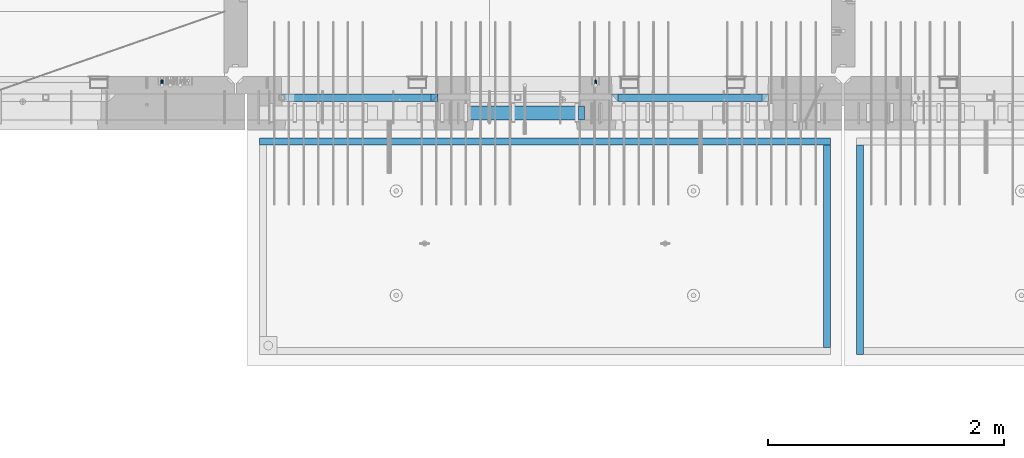
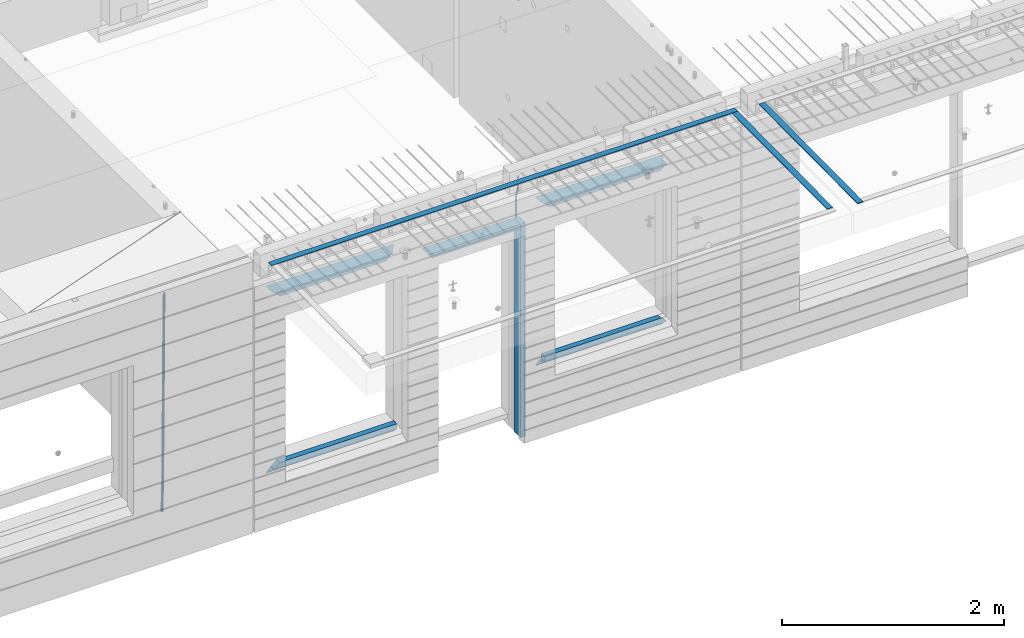
# One storey, part 95 of 352: 15 beams, 4 elements without a shape of their own.
"""IFC2X3 building model written with IfcOpenShell, lengths in millimetres."""

from ifc_helpers import new_model, si_unit, frame, origin_with_axes, place, context, subcontext, project, spatial, faceted_brep, material, type_object, element, aggregate, save


model = new_model("IFC2X3")

# Units and contexts
model_context = context("Model", 3, precision=1e-05, world=origin_with_axes())
body_context = subcontext(model_context, "Body", "Model", "MODEL_VIEW")
ifc_project = project(units=[si_unit("LENGTHUNIT", "METRE", prefix="MILLI"), si_unit("AREAUNIT", "SQUARE_METRE"), si_unit("VOLUMEUNIT", "CUBIC_METRE"), si_unit("MASSUNIT", "GRAM", prefix="KILO"), si_unit("TIMEUNIT", "SECOND"), si_unit("PLANEANGLEUNIT", "RADIAN"), si_unit("SOLIDANGLEUNIT", "STERADIAN"), si_unit("THERMODYNAMICTEMPERATUREUNIT", "DEGREE_CELSIUS"), si_unit("LUMINOUSINTENSITYUNIT", "LUMEN")], contexts=[model_context])

# Site, building, storey
site_placement = place(None, origin_with_axes())
site = spatial("IfcSite", under=ifc_project, at=site_placement, CompositionType="ELEMENT")
building_placement = place(site_placement, origin_with_axes())
building = spatial("IfcBuilding", under=site, at=building_placement, CompositionType="ELEMENT")
storey_placement = place(building_placement, origin_with_axes())
storey = spatial("IfcBuildingStorey", under=building, at=storey_placement, Name="6", CompositionType="ELEMENT", Elevation=0.0)

# Assembly, beam
assembly_1_placement = place(storey_placement, origin_with_axes())
assembly_1 = element("IfcElementAssembly", 1, at=assembly_1_placement, inside=storey, AssemblyPlace="NOTDEFINED", PredefinedType="REINFORCEMENT_UNIT")
ifc_material_1 = material()
beam_type_1 = type_object("IfcBeamType", Name="D20", PredefinedType="NOTDEFINED")
beam_1_placement = place(assembly_1_placement, frame((19710.0073333522, 7925.0, 99407.5000058722), z_axis=(0.000415599999849905, 0.999999913638203, 4.76000000899737e-07), x_axis=(0.0, 0.0, -1.0)))
beam_1 = element("IfcBeam", 2, at=beam_1_placement, type_object=beam_type_1, material=ifc_material_1, Name="JM20", ObjectType="D20", context=body_context, shape_type="Brep", body=[
    faceted_brep([(0.0, -10.0, 0.0), (-4.19531716033816e-08, -7.07106781186667, -7.07106781187031), (113.248091332178, -7.0710684840451, -7.0710678117357), (113.248091314759, -10.0000006713562, -2.51020537689328e-10), (0.0, 0.0, -10.0), (113.248091374131, -6.72178430249915e-07, -9.99999999986903), (4.196772351861e-08, 7.07106781186303, -7.07106781186667), (113.248091416113, 7.07106713968824, -7.07106781173934), (0.0, 10.0, 0.0), (113.248091433488, 9.99999932782521, 1.30967237055302e-10), (4.196772351861e-08, 7.07106781185939, 7.07106781185939), (113.248091416113, 7.0710671396846, 7.071067811994), (0.0, 0.0, 10.0), (113.248091374131, -6.72174792271107e-07, 10.0000000001273), (-4.19531716033816e-08, -7.07106781187031, 7.07106781185939), (113.248091332178, -7.0710684840451, 7.071067811994), (130.699843527167, -7.06993249763036, -4.33745683788584), (128.538066582521, -9.99900540317321, 2.39499413731755), (131.594536475241, 0.00119355250353692, -7.12624594330919), (130.698046432328, 7.07220300913468, -4.33773834422391), (128.535525107087, 10.0009944322555, 2.39459602660281), (126.373748162892, 7.07192152754578, 9.1270470011732), (125.479055214906, 0.000795477419160306, 11.9158361066184), (126.37554525779, -7.07021397921199, 9.12732850753673), (240.336258550378, -7.05529970173666, 30.8729495437874), (238.174481606227, -9.98437260450009, 37.6054005176375), (241.230951498423, 0.0158263482953771, 28.0841604381058), (240.334461455612, 7.0868358050102, 30.8726680369582), (238.171940130502, 10.0156272283348, 37.6050024077231), (236.010163186409, 7.08655432384694, 44.3374533824244), (235.115470238379, 0.0154282738185429, 47.1262424881097), (236.011960281176, -7.05558118289991, 44.3377348892536), (253.461915329972, -7.05444528127919, 32.9289287376414), (253.46191532613, -9.98337746617108, 39.9999965521893), (253.461915339081, 0.0166225284556276, 29.9999965443676), (253.461915348205, 7.08769034247234, 32.9289287273205), (253.461915352003, 10.0166225357716, 39.9999965370152), (253.461915348293, 7.08769035281148, 47.0710643509774), (253.461915339183, 0.0166225430875784, 49.999996544273), (253.46191533003, -7.05444527093641, 47.0710643613093), (1617.47998045172, -7.05444857276962, 32.9289287369675), (1617.47998044467, -9.98338075699212, 39.9999965504549), (1617.47998046874, 0.0166192374708771, 29.9999965449206), (1617.47998048575, 7.08768705096008, 32.9289287291404), (1617.47998049279, 10.0166192430079, 39.9999965393854), (1617.47998048575, 7.08768705878902, 47.071064352871), (1617.47998046874, 0.0166192485448846, 49.9999965449197), (1617.47998045172, -7.05444856494069, 47.0710643606981)], [[[0, 1, 2, 3]], [[1, 4, 5, 2]], [[4, 6, 7, 5]], [[6, 8, 9, 7]], [[8, 10, 11, 9]], [[10, 12, 13, 11]], [[12, 14, 15, 13]], [[14, 0, 3, 15]], [[14, 12, 10, 8, 6, 4, 1, 0]], [[3, 2, 16, 17]], [[2, 5, 18, 16]], [[5, 7, 19, 18]], [[7, 9, 20, 19]], [[9, 11, 21, 20]], [[11, 13, 22, 21]], [[13, 15, 23, 22]], [[15, 3, 17, 23]], [[17, 16, 24, 25]], [[16, 18, 26, 24]], [[18, 19, 27, 26]], [[19, 20, 28, 27]], [[20, 21, 29, 28]], [[21, 22, 30, 29]], [[22, 23, 31, 30]], [[23, 17, 25, 31]], [[25, 24, 32, 33]], [[24, 26, 34, 32]], [[26, 27, 35, 34]], [[27, 28, 36, 35]], [[28, 29, 37, 36]], [[29, 30, 38, 37]], [[30, 31, 39, 38]], [[31, 25, 33, 39]], [[33, 32, 40, 41]], [[32, 34, 42, 40]], [[34, 35, 43, 42]], [[35, 36, 44, 43]], [[36, 37, 45, 44]], [[37, 38, 46, 45]], [[38, 39, 47, 46]], [[39, 33, 41, 47]], [[42, 43, 44, 45, 46, 47, 41, 40]]]),
])

assembly_2_placement = place(storey_placement, origin_with_axes())
assembly_2 = element("IfcElementAssembly", 3, at=assembly_2_placement, inside=storey, AssemblyPlace="NOTDEFINED", PredefinedType="REINFORCEMENT_UNIT")
beam_type_2 = type_object("IfcBeamType", Name="D25", PredefinedType="NOTDEFINED")
beam_2_placement = place(assembly_2_placement, frame((16034.9999999961, 7965.00000227913, 96990.0), z_axis=(0.00020576299992186, -0.999642804629538, -0.0267249099901004), x_axis=(-4.30000201928125e-08, -0.0267249099948059, 0.999642825806181)))
beam_2 = element("IfcBeam", 4, at=beam_2_placement, type_object=beam_type_2, material=ifc_material_1, Name="JM25", ObjectType="D25", context=body_context, shape_type="Brep", body=[
    faceted_brep([(-7.41420080885291e-08, -12.5, -3.63797880709171e-12), (-6.42030499875546e-08, -10.8253175473074, -6.25000000000364), (60.4103898235917, -10.8253175318459, -6.2499999938409), (60.4103898269532, -12.4999999845422, 6.16273609921336e-09), (-3.70782800018787e-08, -6.25000000000364, -10.8253175473074), (60.4103898202884, -6.24999998454587, -10.8253175411446), (-1.45519152283669e-11, -3.63797880709171e-12, -12.5), (60.4103898179019, 1.54577719513327e-08, -12.4999999938373), (3.70637280866504e-08, 6.25, -10.8253175473074), (60.410389817087, 6.25000001545777, -10.825317541141), (6.42030499875546e-08, 10.8253175473001, -6.25000000000364), (60.410389818062, 10.8253175627578, -6.24999999383726), (7.41420080885291e-08, 12.4999999999927, 0.0), (60.4103898205503, 12.5000000154541, 6.16273609921336e-09), (6.42176019027829e-08, 10.8253175473001, 6.24999999999636), (60.4103898238973, 10.8253175627651, 6.2500000061591), (3.70928319171071e-08, 6.24999999999636, 10.8253175473037), (60.4103898272151, 6.25000001546141, 10.8253175534664), (1.45519152283669e-11, -3.63797880709171e-12, 12.4999999999964), (60.4103898296162, 1.54541339725256e-08, 12.5000000061591), (-3.7049176171422e-08, -6.25000000000364, 10.8253175473001), (60.4103898304165, -6.24999998454587, 10.8253175534701), (-6.41884980723262e-08, -10.8253175473074, 6.25), (60.4103898294561, -10.8253175318459, 6.25000000616637), (61.0324985728803, -10.8253175316895, -6.24999999377542), (60.991802792938, -12.4999999843931, 6.22458173893392e-09), (61.0622854283865, -6.24999998437852, -10.8253175410755), (61.0731819955545, 1.5628756955266e-08, -12.4999999937718), (61.0622685480339, 6.25000001562512, -10.8253175410791), (61.032469335245, 10.8253175629216, -6.24999999377178), (60.9917690322181, 12.5000000156033, 6.22458173893392e-09), (60.9510732522613, 10.8253175629034, 6.25000000621731), (60.9212863967696, 6.25000001558874, 10.8253175535247), (60.9103898296162, 1.55814632307738e-08, 12.5000000062137), (60.9213032771368, -6.24999998441126, 10.8253175535174), (60.9511024898966, -10.8253175317113, 6.25000000621731), (61.6545545670233, -10.8253158516927, -6.24189838219536), (61.573166454793, -12.499998414296, 0.00757164385504439), (61.7141257553885, -6.24999822394238, -10.8168280205282), (61.7359179680789, 1.80548886419274e-06, -12.491368569139), (61.7140919992817, 6.25000177601396, -10.8168282403167), (61.6544960997562, 10.8253192428383, -6.2418987628771), (61.5730989426083, 12.5000015856094, 0.0075712042817031), (61.4917108303925, 10.8253190230062, 6.25704123032847), (61.4321396420273, 6.25000139525582, 10.8319708686649), (61.4103474293224, 1.36582457344048e-06, 12.5065114172721), (61.4321733981196, -6.24999860470052, 10.8319710884571), (61.4917692976451, -10.8253160715249, 6.25704161101385), (176.524302641745, -10.8250056210964, -4.74584321979273), (176.442914529529, -12.4996881836996, 1.50362680625403), (176.583873830095, -6.24968799334965, -9.3207728581292), (176.605666042786, 0.000312036081595579, -10.9953134067364), (176.583840074018, 6.25031200660669, -9.32077307791769), (176.524244174492, 10.8256294734347, -4.74584360047811), (176.44284701733, 12.5003118162058, 1.50362636668069), (176.361458905099, 10.8256292535989, 7.75309639272746), (176.301887716749, 6.25031162585219, 12.3280260310676), (176.280095504058, 0.000311596420942806, 14.0025665796711), (176.301921472827, -6.24968837410415, 12.3280262508561), (176.361517372367, -10.8250058409321, 7.75309677341284), (177.085397012124, -10.8250041057399, -4.73853556792164), (176.983633547483, -12.4996867233749, 1.51066909103247), (177.159881729676, -6.24968643771717, -9.31327097355097), (177.187129580227, 0.000313606451527448, -10.987740468332), (177.159839524218, 6.25031356221734, -9.31327130338468), (177.085323910098, 10.8256309887511, -4.73853613920801), (176.983549136537, 12.5003132764905, 1.51066843136869), (176.881785671867, 10.8256306588555, 7.7598730903228), (176.80730095433, 6.25031299082912, 12.3346084959521), (176.780053103794, 0.000312946667690994, 14.0090779907332), (176.807343159802, -6.2496870091054, 12.3346088257895), (176.881858773908, -10.8250044356355, 7.7598736616128), (177.646431799818, -10.8250018318176, -4.72756919822132), (177.524295146417, -12.4996845320202, 1.52123723245313), (177.735828462886, -6.24968410334986, -9.30201312475765), (177.768531371941, 0.00031596292683389, -10.9763759912421), (177.735777808921, 6.25031589654827, -9.30201361973741), (177.646344064575, 10.8256332626152, -4.72757005553649), (177.524193838486, 12.5003154677688, 1.52123624250817), (177.402057185071, 10.8256327675663, 7.77004267317898), (177.312660521988, 6.2503150390985, 12.3444865997226), (177.279957612933, 0.00031497282179771, 14.0188494661961), (177.312711175953, -6.24968496079964, 12.3444870946951), (177.402144920314, -10.8250023268702, 7.77004353049415), (299.377443161706, -10.8245084454466, -2.34813158632096), (299.255306508276, -12.4991911456491, 3.90067484435349), (299.466839824803, -6.24919071697514, -6.92257551286093), (299.499542733873, 0.0008093492979242, -8.59693837933446), (299.466789170867, 6.250809282923, -6.92257600783341), (299.377355426492, 10.8261266489935, -2.34813244364341), (299.255205200388, 12.5008088541435, 3.90067385440125), (299.133068546944, 10.826126153941, 10.1494802850757), (299.043671883861, 6.25080842546959, 14.7239242116229), (299.010968974762, 0.000808359200163977, 16.3982870780892), (299.043722537797, -6.24919157442127, 14.7239247065918), (299.133156282158, -10.8245089404954, 10.1494811423981), (299.98561436501, -10.8245059804758, -2.33624385599614), (299.97179243555, -12.4991882411778, 3.91467976726199), (299.995742293278, -6.24918857328521, -6.91223722345239), (299.999447243041, 0.000811375455668895, -8.58716690387519), (299.995736475976, 6.25081142679483, -6.91223684201032), (299.985604289133, 10.8261291142808, -2.33624319533556), (299.971750386685, 12.5008117588586, 3.91467993563856), (299.957928457196, 10.8261294971744, 10.1656035610831), (299.947800528913, 6.25081208998381, 14.7415969285394), (299.944095579151, 0.00081214124293183, 16.4165266089549), (299.947806346216, -6.24918791008895, 14.7415965471009), (299.957938533058, -10.8245055975785, 10.1656029004225), (300.593832239858, -10.8245078794353, -2.34543881707941), (300.688302931099, -12.4991904788549, 3.90384712594823), (300.524685350189, -6.24919022474205, -6.92023371784308), (300.499390115292, 0.000809814544481924, -8.59472497713432), (300.524724372954, 6.25080977519247, -6.92023401429469), (300.593899829313, 10.8261272150703, -2.34543933054374), (300.688380976673, 12.5008095210287, 3.90384653304136), (300.782851667915, 10.8261269216127, 10.1531324760799), (300.851998557599, 6.25080926691589, 14.7279273768363), (300.877293792495, 0.000809227632998955, 16.4024186361276), (300.851959534804, -6.24919073302226, 14.7279276732806), (300.782784078474, -10.8245081728965, 10.153132989537), (2293.32930409742, -10.8307295605009, -32.4713622331001), (2293.42377478865, -12.5054121599169, -26.2220762900724), (2293.26015720774, -6.2554119058077, -37.0461571338565), (2293.23486197284, -0.00541186651753378, -38.7206483931477), (2293.26019623051, 6.24458809413409, -37.0461574303008), (2293.32937168686, 10.8199055340046, -32.4713627465644), (2293.42385283421, 12.4945878399631, -26.2220768829684), (2293.51832352545, 10.8199052405434, -19.972790939948), (2293.58747041514, 6.24458758585388, -15.3979960391844), (2293.61276565003, -0.00541245343265473, -13.7235047798931), (2293.58743139236, -6.25541241408428, -15.3979957427327), (2293.51825593603, -10.8307298539585, -19.9727904264691), (2294.0420846676, -10.8307317859326, -32.4821379598216), (2294.03681932652, -12.5054140739521, -26.2313442200393), (2294.06778164886, -6.2554144273563, -37.0583666982457), (2294.10702478497, -0.00541458957013674, -38.7338336404937), (2294.14929890928, 6.24458531819619, -37.0595987724118), (2294.18327670435, 10.8199028679592, -32.4842719748667), (2294.1998538474, 12.4945854171456, -26.2338083683717), (2294.19458850632, 10.819903129126, -19.9830146285858), (2294.16889152506, 6.24458577054975, -15.4067858901581), (2294.12964838895, -0.0054140672327776, -13.7313189479173), (2294.08737426462, -6.2554139749991, -15.4055538159919), (2294.05339646956, -10.8307315247621, -19.9808806135297), (2294.75482297382, -10.84002603931, -32.4726521173216), (2294.64982751427, -12.513407826169, -26.2231856868602), (2294.87535820232, -6.26594539088183, -37.0476186524102), (2294.97913588268, -0.0167870967634371, -38.7222267036377), (2295.0383488692, 6.23299192477134, -37.0477663960555), (2295.03713108998, 10.8087684320271, -32.4729080168181), (2294.97580884799, 12.4844668051373, -26.2234811741473), (2294.87081338844, 10.8110850182784, -19.9740147436787), (2294.7502781599, 6.23700436985018, -15.3990482086047), (2294.64650047956, -0.0121539242718427, -13.7244401573698), (2294.58728749304, -6.26193294580662, -15.3989004649666), (2294.58850527227, -10.8377094530588, -19.9737588441894), (2316.44667268227, -11.1228921988077, -32.1839550346631), (2316.34167722271, -12.7962739856739, -25.9344886042054), (2316.56720791078, -6.54881155039038, -36.7589215697517), (2316.67098559113, -0.299653256264719, -38.4335296209792), (2316.73019857766, 5.95012576527006, -36.759069313397), (2316.72898079845, 10.5259022725259, -32.1842109341669), (2316.66765855643, 12.2016006456361, -25.9347840914961), (2316.56266309689, 10.5282188587698, -19.6853176610275), (2316.44212786836, 5.95413821035254, -15.1103511259389), (2316.33835018802, -0.295020083769487, -13.4357430747186), (2316.27913720149, -6.54479910530426, -15.1102033823008), (2316.28035498071, -11.1205756125637, -19.685061761531), (2317.13234804722, -11.1318335458927, -32.1748293731798), (2317.04181141085, -12.8054038787741, -25.9251705100723), (2317.2154741603, -6.5572650749491, -36.7502937866229), (2317.26891617525, -0.307450393454928, -38.4255717558117), (2317.27835434731, 5.94297770185585, -36.7517739018112), (2317.24125972588, 10.5192220504723, -32.1773930078925), (2317.16757178486, 12.1950816748285, -25.9281307404563), (2317.0770351485, 10.5215113419545, -19.6784718773561), (2316.99390903539, 5.94694287101083, -15.1030074639057), (2316.94046702047, -0.302871810494253, -13.4277294947169), (2316.9310288484, -6.55329990579412, -15.1015273487101), (2316.96812346982, -11.1295442544142, -19.6759082426288), (2317.81808136747, -11.1298054502913, -32.1659056455355), (2317.74200467508, -12.803315894289, -25.9160547315114), (2317.86379538118, -6.55536082026447, -36.7418676070083), (2317.8668976831, -0.305700748642266, -38.417815303761), (2317.82655701396, 5.94458339541234, -36.7446799039099), (2317.75358262347, 10.5207330230332, -32.1707766866384), (2317.66752794063, 12.1965725370646, -25.9216793252963), (2317.59145124823, 10.5230620930706, -19.6718284112721), (2317.54573723453, 5.94861746304377, -15.0958664497994), (2317.54263493262, -0.301042608574789, -13.4199187530394), (2317.58297560175, -6.55132675263303, -15.0930541529051), (2317.65594999224, -11.1274763802539, -19.6669573701693), (2417.81884292323, -10.831603083323, -30.8687911350135), (2417.74276623082, -12.505113527317, -24.618940220982), (2417.86455693691, -6.25715845329614, -35.4447530964935), (2417.86765923884, -0.00749838167394046, -37.1207007932499), (2417.82731856969, 6.24278576237703, -35.4475653933878), (2417.75434417921, 10.8189353900088, -30.8736621761236), (2417.66828949639, 12.494774904033, -24.6245648147851), (2417.59221280397, 10.8212644600353, -18.3747139007501), (2417.54649879028, 6.2468198300121, -13.79875193927), (2417.54339648837, -0.00284024161010166, -12.1228042425173), (2417.5837371575, -6.25312438566107, -13.795939642383), (2417.65671154798, -10.8292740132893, -18.3698428596399)], [[[0, 1, 2, 3]], [[1, 4, 5, 2]], [[4, 6, 7, 5]], [[6, 8, 9, 7]], [[8, 10, 11, 9]], [[10, 12, 13, 11]], [[12, 14, 15, 13]], [[14, 16, 17, 15]], [[16, 18, 19, 17]], [[18, 20, 21, 19]], [[20, 22, 23, 21]], [[22, 0, 3, 23]], [[22, 20, 18, 16, 14, 12, 10, 8, 6, 4, 1, 0]], [[3, 2, 24, 25]], [[2, 5, 26, 24]], [[5, 7, 27, 26]], [[7, 9, 28, 27]], [[9, 11, 29, 28]], [[11, 13, 30, 29]], [[13, 15, 31, 30]], [[15, 17, 32, 31]], [[17, 19, 33, 32]], [[19, 21, 34, 33]], [[21, 23, 35, 34]], [[23, 3, 25, 35]], [[25, 24, 36, 37]], [[24, 26, 38, 36]], [[26, 27, 39, 38]], [[27, 28, 40, 39]], [[28, 29, 41, 40]], [[29, 30, 42, 41]], [[30, 31, 43, 42]], [[31, 32, 44, 43]], [[32, 33, 45, 44]], [[33, 34, 46, 45]], [[34, 35, 47, 46]], [[35, 25, 37, 47]], [[37, 36, 48, 49]], [[36, 38, 50, 48]], [[38, 39, 51, 50]], [[39, 40, 52, 51]], [[40, 41, 53, 52]], [[41, 42, 54, 53]], [[42, 43, 55, 54]], [[43, 44, 56, 55]], [[44, 45, 57, 56]], [[45, 46, 58, 57]], [[46, 47, 59, 58]], [[47, 37, 49, 59]], [[49, 48, 60, 61]], [[48, 50, 62, 60]], [[50, 51, 63, 62]], [[51, 52, 64, 63]], [[52, 53, 65, 64]], [[53, 54, 66, 65]], [[54, 55, 67, 66]], [[55, 56, 68, 67]], [[56, 57, 69, 68]], [[57, 58, 70, 69]], [[58, 59, 71, 70]], [[59, 49, 61, 71]], [[61, 60, 72, 73]], [[60, 62, 74, 72]], [[62, 63, 75, 74]], [[63, 64, 76, 75]], [[64, 65, 77, 76]], [[65, 66, 78, 77]], [[66, 67, 79, 78]], [[67, 68, 80, 79]], [[68, 69, 81, 80]], [[69, 70, 82, 81]], [[70, 71, 83, 82]], [[71, 61, 73, 83]], [[73, 72, 84, 85]], [[72, 74, 86, 84]], [[74, 75, 87, 86]], [[75, 76, 88, 87]], [[76, 77, 89, 88]], [[77, 78, 90, 89]], [[78, 79, 91, 90]], [[79, 80, 92, 91]], [[80, 81, 93, 92]], [[81, 82, 94, 93]], [[82, 83, 95, 94]], [[83, 73, 85, 95]], [[85, 84, 96, 97]], [[84, 86, 98, 96]], [[86, 87, 99, 98]], [[87, 88, 100, 99]], [[88, 89, 101, 100]], [[89, 90, 102, 101]], [[90, 91, 103, 102]], [[91, 92, 104, 103]], [[92, 93, 105, 104]], [[93, 94, 106, 105]], [[94, 95, 107, 106]], [[95, 85, 97, 107]], [[97, 96, 108, 109]], [[96, 98, 110, 108]], [[98, 99, 111, 110]], [[99, 100, 112, 111]], [[100, 101, 113, 112]], [[101, 102, 114, 113]], [[102, 103, 115, 114]], [[103, 104, 116, 115]], [[104, 105, 117, 116]], [[105, 106, 118, 117]], [[106, 107, 119, 118]], [[107, 97, 109, 119]], [[109, 108, 120, 121]], [[108, 110, 122, 120]], [[110, 111, 123, 122]], [[111, 112, 124, 123]], [[112, 113, 125, 124]], [[113, 114, 126, 125]], [[114, 115, 127, 126]], [[115, 116, 128, 127]], [[116, 117, 129, 128]], [[117, 118, 130, 129]], [[118, 119, 131, 130]], [[119, 109, 121, 131]], [[121, 120, 132, 133]], [[120, 122, 134, 132]], [[122, 123, 135, 134]], [[123, 124, 136, 135]], [[124, 125, 137, 136]], [[125, 126, 138, 137]], [[126, 127, 139, 138]], [[127, 128, 140, 139]], [[128, 129, 141, 140]], [[129, 130, 142, 141]], [[130, 131, 143, 142]], [[131, 121, 133, 143]], [[133, 132, 144, 145]], [[132, 134, 146, 144]], [[134, 135, 147, 146]], [[135, 136, 148, 147]], [[136, 137, 149, 148]], [[137, 138, 150, 149]], [[138, 139, 151, 150]], [[139, 140, 152, 151]], [[140, 141, 153, 152]], [[141, 142, 154, 153]], [[142, 143, 155, 154]], [[143, 133, 145, 155]], [[145, 144, 156, 157]], [[144, 146, 158, 156]], [[146, 147, 159, 158]], [[147, 148, 160, 159]], [[148, 149, 161, 160]], [[149, 150, 162, 161]], [[150, 151, 163, 162]], [[151, 152, 164, 163]], [[152, 153, 165, 164]], [[153, 154, 166, 165]], [[154, 155, 167, 166]], [[155, 145, 157, 167]], [[157, 156, 168, 169]], [[156, 158, 170, 168]], [[158, 159, 171, 170]], [[159, 160, 172, 171]], [[160, 161, 173, 172]], [[161, 162, 174, 173]], [[162, 163, 175, 174]], [[163, 164, 176, 175]], [[164, 165, 177, 176]], [[165, 166, 178, 177]], [[166, 167, 179, 178]], [[167, 157, 169, 179]], [[169, 168, 180, 181]], [[168, 170, 182, 180]], [[170, 171, 183, 182]], [[171, 172, 184, 183]], [[172, 173, 185, 184]], [[173, 174, 186, 185]], [[174, 175, 187, 186]], [[175, 176, 188, 187]], [[176, 177, 189, 188]], [[177, 178, 190, 189]], [[178, 179, 191, 190]], [[179, 169, 181, 191]], [[181, 180, 192, 193]], [[180, 182, 194, 192]], [[182, 183, 195, 194]], [[183, 184, 196, 195]], [[184, 185, 197, 196]], [[185, 186, 198, 197]], [[186, 187, 199, 198]], [[187, 188, 200, 199]], [[188, 189, 201, 200]], [[189, 190, 202, 201]], [[190, 191, 203, 202]], [[191, 181, 193, 203]], [[194, 195, 196, 197, 198, 199, 200, 201, 202, 203, 193, 192]]]),
])
aggregate(assembly_2, [beam_2])

assembly_3_placement = place(storey_placement, origin_with_axes())
assembly_3 = element("IfcElementAssembly", 5, at=assembly_3_placement, inside=storey, AssemblyPlace="NOTDEFINED", PredefinedType="REINFORCEMENT_UNIT")
ifc_material_2 = material(Name="CONCRETE/Concrete_Undefined")
beam_type_3 = type_object("IfcBeamType", PredefinedType="NOTDEFINED")
beam_3_placement = place(assembly_3_placement, frame((21949.9413897781, 7420.05314849477, 99725.6636561746), z_axis=(2.93000000986506e-07, -0.00901322400064496, 0.999959380071525), x_axis=(3.25389999851993e-05, -0.999959379542196, -0.00901322399586982)))
beam_3 = element("IfcBeam", 6, at=beam_3_placement, type_object=beam_type_3, material=ifc_material_2, context=body_context, shape_type="Brep", body=[
    faceted_brep([(2.5465851649642e-11, 29.9999999999982, -4.99999999998545), (-2.91038304567337e-11, 29.9999999999982, 5.0), (1775.16788460852, 30.0000000000036, 5.0), (1775.16788460861, 30.0000000000036, -4.99999999998545), (-2.5465851649642e-11, -30.0000000000018, 5.0), (1775.16788460852, -29.9999999999927, 5.0), (2.72848410531878e-11, -30.0000000000018, -4.99999999998545), (1775.16788460861, -29.9999999999927, -4.99999999998545)], [[[0, 1, 2, 3]], [[1, 4, 5, 2]], [[4, 6, 7, 5]], [[6, 0, 3, 7]], [[5, 7, 3, 2]], [[6, 4, 1, 0]]]),
])
aggregate(assembly_3, [beam_3])

# Assembly, beams
assembly_4_placement = place(storey_placement, origin_with_axes())
assembly_4 = element("IfcElementAssembly", 7, at=assembly_4_placement, inside=storey, AssemblyPlace="NOTDEFINED", PredefinedType="REINFORCEMENT_UNIT")
beam_4_placement = place(assembly_4_placement, frame((21670.0013901233, 7419.93998011425, 99723.2790373903), z_axis=(-5.99999839176643e-09, -0.0089070149978186, 0.99996033175513), x_axis=(-7.26999998800451e-07, -0.999960331754865, -0.00890701499781462)))
beam_4 = element("IfcBeam", 8, at=beam_4_placement, type_object=beam_type_3, material=ifc_material_2, context=body_context, shape_type="Brep", body=[
    faceted_brep([(2.5465851649642e-11, 29.9999999999982, -4.99999999998545), (-2.91038304567337e-11, 29.9999999999982, 5.0), (1714.98205429674, 30.0, 5.00000000001455), (1714.98205429674, 30.0000000000036, -4.99999999998545), (-2.5465851649642e-11, -30.0000000000018, 5.0), (1714.98205429674, -30.0, 5.00000000001455), (2.72848410531878e-11, -30.0000000000018, -4.99999999998545), (1714.98205429674, -29.9999999999964, -4.99999999998545)], [[[0, 1, 2, 3]], [[1, 4, 5, 2]], [[4, 6, 7, 5]], [[6, 0, 3, 7]], [[5, 7, 3, 2]], [[6, 4, 1, 0]]]),
])
beam_5_placement = place(assembly_4_placement, frame((21700.0027302922, 7449.93184428734, 99723.6588442717), z_axis=(0.0, 0.0, 1.0), x_axis=(-0.999999999888168, 1.49249999983396e-05, 9.53000001204034e-07)))
beam_5 = element("IfcBeam", 9, at=beam_5_placement, type_object=beam_type_3, material=ifc_material_2, context=body_context, shape_type="Brep", body=[
    faceted_brep([(2.5465851649642e-11, 29.9999999999982, -4.99999999998545), (-2.91038304567337e-11, 29.9999999999982, 5.0), (4840.00999799337, 29.9999999999991, 5.0), (4840.00999799337, 29.9999999999982, -5.00000000001455), (-2.5465851649642e-11, -30.0000000000018, 5.0), (4840.00999799337, -30.0000000000009, 5.0), (2.72848410531878e-11, -30.0000000000018, -4.99999999998545), (4840.00999799337, -30.0000000000009, -5.0)], [[[0, 1, 2, 3]], [[1, 4, 5, 2]], [[4, 6, 7, 5]], [[6, 0, 3, 7]], [[5, 7, 3, 2]], [[6, 4, 1, 0]]]),
])
aggregate(assembly_4, [beam_4, beam_5])

# Beam
ifc_material_3 = material(Name="CONCRETE/C35/45")
beam_type_4 = type_object("IfcBeamType", PredefinedType="NOTDEFINED")
beam_6_placement = place(assembly_1_placement, frame((17044.9994828029, 7820.0, 99145.0), z_axis=(0.0, 0.0, -1.0), x_axis=(1.0, 0.0, 0.0)))
beam_6 = element("IfcBeam", 10, at=beam_6_placement, type_object=beam_type_4, material=ifc_material_3, Name="SK", context=body_context, shape_type="Brep", body=[
    faceted_brep([(0.0, -30.0, -30.0), (49.817662327685, -30.0, 30.0), (49.817662327685, 30.0, 30.0), (1330.00114440918, -30.0, -30.0), (1280.18348208149, -30.0, 30.0), (1280.18348208149, 30.0, 30.0)], [[[0, 1, 2]], [[1, 0, 3, 4]], [[2, 1, 4, 5]], [[0, 2, 5, 3]], [[4, 3, 5]]]),
])

beam_7_placement = place(assembly_1_placement, frame((17104.9994828029, 7820.0, 99085.0), z_axis=(0.0, 0.0, -1.0), x_axis=(1.0, 0.0, 0.0)))
beam_7 = element("IfcBeam", 11, at=beam_7_placement, type_object=beam_type_4, material=ifc_material_3, Name="SK", context=body_context, shape_type="Brep", body=[
    faceted_brep([(0.0, -30.0, -30.0), (53.0959879499314, -30.0, 24.0540540540678), (54.6888675884184, 30.0, 25.6756756756804), (0.0, 30.0, -30.0), (1210.00114440918, -30.0, -30.0), (1156.90515645927, -30.0, 24.0540540540678), (1155.31227682078, 30.0, 25.6756756756804), (1210.00114440918, 30.0, -30.0)], [[[0, 1, 2, 3]], [[1, 0, 4, 5]], [[2, 1, 5, 6]], [[3, 2, 6, 7]], [[0, 3, 7, 4]], [[6, 5, 4, 7]]]),
])

beam_8_placement = place(assembly_1_placement, frame((18375.0006272121, 7820.0, 97150.0), z_axis=(0.0, 0.0, 1.0), x_axis=(-1.0, 3.00000001838171e-08, 0.0)))
beam_8 = element("IfcBeam", 12, at=beam_8_placement, type_object=beam_type_4, material=ifc_material_3, Name="SK", context=body_context, shape_type="Brep", body=[
    faceted_brep([(0.0, -30.0, 30.0), (-5.28234522789717e-09, 30.0, 30.0), (0.0, -30.0, -30.0), (1280.18348208149, -30.0, 30.0), (1280.18348208149, 30.0, 30.0), (1330.00114440918, -30.0, -30.0)], [[[0, 1, 2]], [[1, 0, 3, 4]], [[2, 1, 4, 5]], [[0, 2, 5, 3]], [[3, 5, 4]]]),
])

beam_9_placement = place(assembly_1_placement, frame((18375.0006272121, 7820.0, 97210.0), z_axis=(0.0, 0.0, 1.0), x_axis=(-1.0, 3.00000001838171e-08, 0.0)))
beam_9 = element("IfcBeam", 13, at=beam_9_placement, type_object=beam_type_4, material=ifc_material_3, Name="SK", context=body_context, shape_type="Brep", body=[
    faceted_brep([(0.0, -30.0, -30.0), (0.0, -30.0, 30.0), (-5.28234522789717e-09, 30.0, 30.0), (0.0, 30.0, -30.0), (4.05405405405327, -30.0, 30.0), (5.67567567567312, 30.0, 30.0), (4.05405405404963, -30.0, 24.0540540540533), (5.67567567567312, 30.0, 25.6756756756804), (1215.31227682077, 30.0, 25.6756756756804), (1270.00114440918, 30.0, -30.0), (1270.00114440918, -30.0, -30.0), (1216.90515645926, -30.0, 24.0540540540678)], [[[0, 1, 2, 3]], [[2, 1, 4, 5]], [[4, 6, 7, 5]], [[3, 2, 5, 7, 8, 9]], [[0, 3, 9, 10]], [[6, 4, 1, 0, 10, 11]], [[7, 6, 11, 8]], [[10, 9, 8, 11]]]),
])

beam_10_placement = place(assembly_1_placement, frame((19845.0006272121, 7820.0, 99145.0), z_axis=(0.0, 0.0, -1.0), x_axis=(1.0, 0.0, 0.0)))
beam_10 = element("IfcBeam", 14, at=beam_10_placement, type_object=beam_type_4, material=ifc_material_3, Name="SK", context=body_context, shape_type="Brep", body=[
    faceted_brep([(0.0, -30.0, -30.0), (49.817662327685, -30.0, 30.0), (49.817662327685, 30.0, 30.0), (1329.99923706055, -30.0, -30.0), (1280.18157473286, -30.0, 30.0), (1280.18157473286, 30.0, 30.0)], [[[0, 1, 2]], [[1, 0, 3, 4]], [[2, 1, 4, 5]], [[0, 2, 5, 3]], [[4, 3, 5]]]),
])

beam_11_placement = place(assembly_1_placement, frame((19905.0006272121, 7820.0, 99085.0), z_axis=(0.0, 0.0, -1.0), x_axis=(1.0, 0.0, 0.0)))
beam_11 = element("IfcBeam", 15, at=beam_11_placement, type_object=beam_type_4, material=ifc_material_3, Name="SK", context=body_context, shape_type="Brep", body=[
    faceted_brep([(0.0, -30.0, -30.0), (53.0959879499314, -30.0, 24.0540540540678), (54.6888675884184, 30.0, 25.6756756756804), (0.0, 30.0, -30.0), (1269.99923706055, -30.0, -30.0), (1211.91971158142, -30.0, 24.0540540540533), (1210.17732581704, 30.0, 25.6756756756804), (1269.99923706055, 30.0, -30.0)], [[[0, 1, 2, 3]], [[1, 0, 4, 5]], [[2, 1, 5, 6]], [[3, 2, 6, 7]], [[0, 3, 7, 4]], [[6, 5, 4, 7]]]),
])

beam_12_placement = place(assembly_1_placement, frame((21174.9998642727, 7820.0, 97350.0), z_axis=(0.0, 0.0, 1.0), x_axis=(-1.0, 3.00000001838171e-08, 0.0)))
beam_12 = element("IfcBeam", 16, at=beam_12_placement, type_object=beam_type_4, material=ifc_material_3, Name="SK", context=body_context, shape_type="Brep", body=[
    faceted_brep([(1280.18157473286, -30.0, 30.0), (1329.99923706055, -30.0, -30.0), (1280.18157473286, 30.0, 30.0), (0.0, -30.0, -30.0), (49.817662327685, 30.0, 30.0), (49.817662327685, -30.0, 30.0)], [[[0, 1, 2]], [[3, 4, 2, 1]], [[4, 5, 0, 2]], [[5, 3, 1, 0]], [[3, 5, 4]]]),
])

beam_13_placement = place(assembly_1_placement, frame((21174.9998642727, 7820.0, 97410.0), z_axis=(0.0, 0.0, 1.0), x_axis=(-1.0, 3.00000001838171e-08, 0.0)))
beam_13 = element("IfcBeam", 17, at=beam_13_placement, type_object=beam_type_4, material=ifc_material_3, Name="SK", context=body_context, shape_type="Brep", body=[
    faceted_brep([(1269.99923706055, -30.0, -30.0), (1269.99923706055, 30.0, -30.0), (1269.99923706055, 30.0, 25.6756756756804), (1269.99923706055, -30.0, 24.0540540540678), (0.0, -30.0, -30.0), (0.0, 30.0, -30.0), (59.8219112435072, 30.0, 25.6756756756804), (58.0795254791192, -30.0, 24.0540540540533)], [[[0, 1, 2, 3]], [[4, 5, 1, 0]], [[2, 1, 5, 6]], [[3, 2, 6, 7]], [[0, 3, 7, 4]], [[6, 5, 4, 7]]]),
])

ifc_material_4 = material(Name="TIMBER")
beam_type_5 = type_object("IfcBeamType", Name="50X120", PredefinedType="NOTDEFINED")
beam_14_placement = place(assembly_1_placement, frame((18604.9998642727, 7690.0, 99080.0), z_axis=(0.0, 0.0, -1.0), x_axis=(1.0, 0.0, 0.0)))
beam_14 = element("IfcBeam", 18, at=beam_14_placement, type_object=beam_type_5, material=ifc_material_4, ObjectType="50X120", context=body_context, shape_type="Brep", body=[
    faceted_brep([(1009.99961853027, -60.0, 25.0), (1009.99961853027, -60.0, -25.0), (1009.99961853027, 60.0, -25.0), (1009.99961853027, 60.0, 25.0), (50.0000000000036, -60.0, 25.0), (0.0, -60.0, -25.0), (0.0, 60.0, -25.0), (50.0000000000036, 60.0, 25.0)], [[[0, 1, 2, 3]], [[1, 0, 4, 5]], [[2, 1, 5, 6]], [[3, 2, 6, 7]], [[0, 3, 7, 4]], [[6, 5, 4, 7]]]),
])

beam_15_placement = place(assembly_1_placement, frame((19589.9994828029, 7690.0, 99105.0), z_axis=(-1.0, 3.00000001838171e-08, 0.0), x_axis=(0.0, 0.0, -1.0)))
beam_15 = element("IfcBeam", 19, at=beam_15_placement, type_object=beam_type_5, material=ifc_material_4, ObjectType="50X120", context=body_context, shape_type="Brep", body=[
    faceted_brep([(0.0, 60.0, -25.0), (0.0, 60.0, 25.0), (2345.0, 60.0, 25.0), (2345.0, 60.0, -25.0), (0.0, -60.0, 25.0), (2345.0, -60.0, 25.0), (0.0, -60.0, -25.0), (2345.0, -60.0, -25.0)], [[[0, 1, 2, 3]], [[1, 4, 5, 2]], [[4, 6, 7, 5]], [[6, 0, 3, 7]], [[5, 7, 3, 2]], [[6, 4, 1, 0]]]),
])

aggregate(assembly_1, [beam_14, beam_15, beam_1, beam_6, beam_7, beam_8, beam_9, beam_10, beam_11, beam_12, beam_13])

save(model, "model.ifc")
